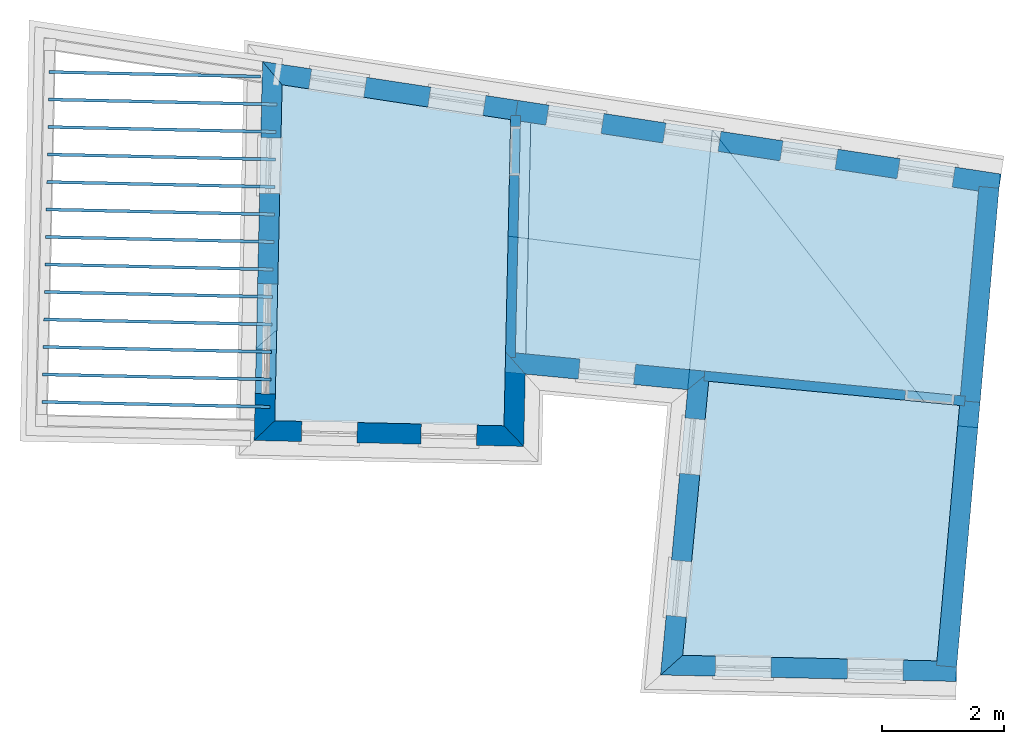
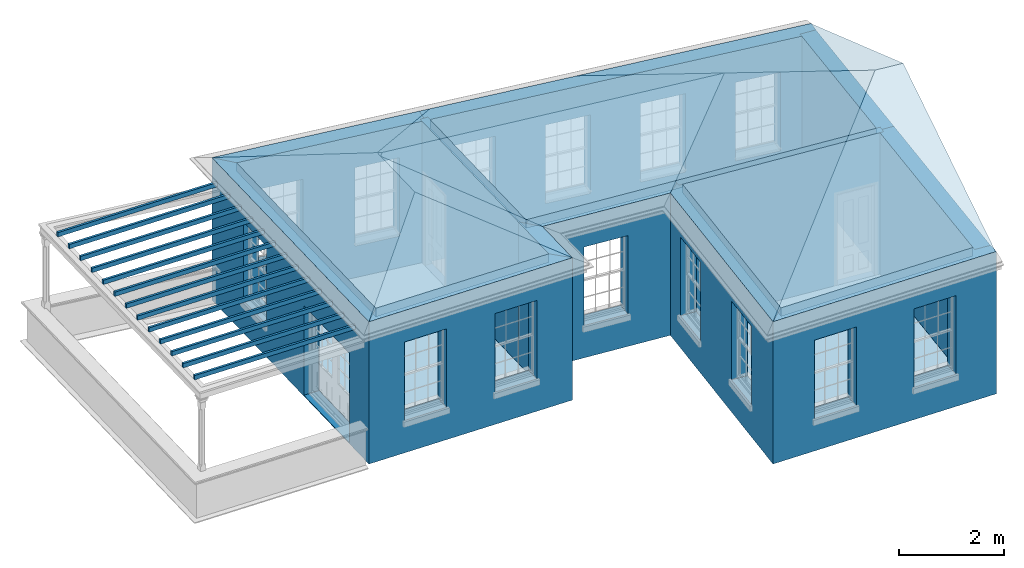
# One storey, part 1 of 12: 18 slabs, 12 walls, 3 roofs, 17 openings.
"""IFC2X3 building model written with IfcOpenShell, lengths in metres."""

from ifc_helpers import new_model, si_unit, frame, origin, place, context, subcontext, project, spatial, polyline, outline, extrude, faceted_brep, material, layer, layer_set, layer_usage, element, save


model = new_model("IFC2X3")

# Units and contexts
model_context = context("Model", 3, world=origin())
body_context = subcontext(model_context, "Body", "Model", "MODEL_VIEW")
ifc_project = project(units=[si_unit("PLANEANGLEUNIT", "RADIAN"), si_unit("MASSUNIT", "GRAM", prefix="KILO"), si_unit("FORCEUNIT", "NEWTON", prefix="KILO"), si_unit("LENGTHUNIT", "METRE")], contexts=[model_context])

# Site, building, storey
site_placement = place(None, origin())
site = spatial("IfcSite", under=ifc_project, at=site_placement, CompositionType="ELEMENT")
building_placement = place(None, origin())
building = spatial("IfcBuilding", under=site, at=building_placement, Name="Building plot-18", CompositionType="ELEMENT")
storey_placement = place(None, frame((0.0, 0.0, 9.9)))
storey = spatial("IfcBuildingStorey", under=building, at=storey_placement, Name="Floor 2", CompositionType="ELEMENT", Elevation=9.9)

# Slabs
slab_1_placement = place(storey_placement, frame((0.0, 0.0, 3.1)))
element("IfcSlab", 1, at=slab_1_placement, inside=storey, Name="Slab", ObjectType="Slab", PredefinedType="FLOOR", context=body_context, shape_type="SweptSolid", body=[
    extrude(outline(polyline([(96.7792255874086, 16.8916819408247), (100.939309623709, 16.8006913200882), (101.309526101752, 20.9794066379798), (97.2057969153529, 21.3743988576596), (96.7792255874086, 16.8916819408247)])), origin(), (0.0, 0.0, 1.0), 0.2),
])
slab_2_placement = place(storey_placement, frame((0.0, 0.0, 3.1)))
element("IfcSlab", 2, at=slab_2_placement, inside=storey, Name="Slab", ObjectType="Slab", PredefinedType="FLOOR", context=body_context, shape_type="SweptSolid", body=[
    extrude(outline(polyline([(93.9652937343678, 25.6552895166051), (90.2260155594004, 26.2254654944291), (90.1057958794453, 20.7290311654569), (93.8557511466322, 20.6470110056427), (93.9652937343678, 25.6552895166051)])), origin(), (0.0, 0.0, 1.0), 0.2),
])
slab_3_placement = place(storey_placement, frame((0.0, 0.0, 2.8)))
element("IfcSlab", 3, at=slab_3_placement, inside=storey, Name="Slab", ObjectType="Slab", PredefinedType="FLOOR", context=body_context, shape_type="SweptSolid", body=[
    extrude(outline(polyline([(86.4150109549581, 26.4611877456726), (86.4139176012794, 26.4111997013246), (89.8699378094766, 26.3356085783382), (89.8710311631553, 26.3855966226862), (86.4150109549581, 26.4611877456726)])), origin(), (0.0, 0.0, 1.0), 0.1),
])
slab_4_placement = place(storey_placement, frame((0.0, 0.0, 2.8)))
element("IfcSlab", 4, at=slab_4_placement, inside=storey, Name="Slab", ObjectType="Slab", PredefinedType="FLOOR", context=body_context, shape_type="SweptSolid", body=[
    extrude(outline(polyline([(86.4051707718502, 26.0112953465409), (86.4040774181715, 25.961307302193), (90.1384321710414, 25.8796283615637), (90.1395255247201, 25.9296164059116), (86.4051707718502, 26.0112953465409)])), origin(), (0.0, 0.0, 1.0), 0.1),
])
slab_5_placement = place(storey_placement, frame((0.0, 0.0, 2.8)))
element("IfcSlab", 5, at=slab_5_placement, inside=storey, Name="Slab", ObjectType="Slab", PredefinedType="FLOOR", context=body_context, shape_type="SweptSolid", body=[
    extrude(outline(polyline([(86.3953305887422, 25.5614029474093), (86.3942372350636, 25.5114149030614), (90.1285919879335, 25.4297359624321), (90.1296853416121, 25.47972400678), (86.3953305887422, 25.5614029474093)])), origin(), (0.0, 0.0, 1.0), 0.1),
])
slab_6_placement = place(storey_placement, frame((0.0, 0.0, 2.8)))
element("IfcSlab", 6, at=slab_6_placement, inside=storey, Name="Slab", ObjectType="Slab", PredefinedType="FLOOR", context=body_context, shape_type="SweptSolid", body=[
    extrude(outline(polyline([(86.3854904056343, 25.1115105482777), (86.3843970519556, 25.0615225039298), (90.1187518048255, 24.9798435633005), (90.1198451585042, 25.0298316076484), (86.3854904056343, 25.1115105482777)])), origin(), (0.0, 0.0, 1.0), 0.1),
])
slab_7_placement = place(storey_placement, frame((0.0, 0.0, 2.8)))
element("IfcSlab", 7, at=slab_7_placement, inside=storey, Name="Slab", ObjectType="Slab", PredefinedType="FLOOR", context=body_context, shape_type="SweptSolid", body=[
    extrude(outline(polyline([(86.3756502225263, 24.6616181491461), (86.3745568688477, 24.6116301047981), (90.1089116217176, 24.5299511641688), (90.1100049753963, 24.5799392085168), (86.3756502225263, 24.6616181491461)])), origin(), (0.0, 0.0, 1.0), 0.1),
])
slab_8_placement = place(storey_placement, frame((0.0, 0.0, 2.8)))
element("IfcSlab", 8, at=slab_8_placement, inside=storey, Name="Slab", ObjectType="Slab", PredefinedType="FLOOR", context=body_context, shape_type="SweptSolid", body=[
    extrude(outline(polyline([(86.3658100394184, 24.2117257500145), (86.3647166857397, 24.1617377056665), (90.0990714386096, 24.0800587650372), (90.1001647922883, 24.1300468093852), (86.3658100394184, 24.2117257500145)])), origin(), (0.0, 0.0, 1.0), 0.1),
])
slab_9_placement = place(storey_placement, frame((0.0, 0.0, 2.8)))
element("IfcSlab", 9, at=slab_9_placement, inside=storey, Name="Slab", ObjectType="Slab", PredefinedType="FLOOR", context=body_context, shape_type="SweptSolid", body=[
    extrude(outline(polyline([(86.3559698563105, 23.7618333508829), (86.3548765026318, 23.7118453065349), (90.0892312555017, 23.6301663659056), (90.0903246091804, 23.6801544102536), (86.3559698563105, 23.7618333508829)])), origin(), (0.0, 0.0, 1.0), 0.1),
])
slab_10_placement = place(storey_placement, frame((0.0, 0.0, 2.8)))
element("IfcSlab", 10, at=slab_10_placement, inside=storey, Name="Slab", ObjectType="Slab", PredefinedType="FLOOR", context=body_context, shape_type="SweptSolid", body=[
    extrude(outline(polyline([(86.3461296732025, 23.3119409517512), (86.3450363195239, 23.2619529074033), (90.0793910723938, 23.180273966774), (90.0804844260724, 23.2302620111219), (86.3461296732025, 23.3119409517512)])), origin(), (0.0, 0.0, 1.0), 0.1),
])
slab_11_placement = place(storey_placement, frame((0.0, 0.0, 2.8)))
element("IfcSlab", 11, at=slab_11_placement, inside=storey, Name="Slab", ObjectType="Slab", PredefinedType="FLOOR", context=body_context, shape_type="SweptSolid", body=[
    extrude(outline(polyline([(86.3362894900946, 22.8620485526196), (86.3351961364159, 22.8120605082717), (90.0695508892858, 22.7303815676424), (90.0706442429645, 22.7803696119903), (86.3362894900946, 22.8620485526196)])), origin(), (0.0, 0.0, 1.0), 0.1),
])
slab_12_placement = place(storey_placement, frame((0.0, 0.0, 2.8)))
element("IfcSlab", 12, at=slab_12_placement, inside=storey, Name="Slab", ObjectType="Slab", PredefinedType="FLOOR", context=body_context, shape_type="SweptSolid", body=[
    extrude(outline(polyline([(86.3264493069867, 22.412156153488), (86.325355953308, 22.3621681091401), (90.0597107061779, 22.2804891685108), (90.0608040598566, 22.3304772128587), (86.3264493069867, 22.412156153488)])), origin(), (0.0, 0.0, 1.0), 0.1),
])
slab_13_placement = place(storey_placement, frame((0.0, 0.0, 2.8)))
element("IfcSlab", 13, at=slab_13_placement, inside=storey, Name="Slab", ObjectType="Slab", PredefinedType="FLOOR", context=body_context, shape_type="SweptSolid", body=[
    extrude(outline(polyline([(86.3166091238787, 21.9622637543564), (86.3155157702001, 21.9122757100084), (90.0498705230699, 21.8305967693791), (90.0509638767486, 21.8805848137271), (86.3166091238787, 21.9622637543564)])), origin(), (0.0, 0.0, 1.0), 0.1),
])
slab_14_placement = place(storey_placement, frame((0.0, 0.0, 2.8)))
element("IfcSlab", 14, at=slab_14_placement, inside=storey, Name="Slab", ObjectType="Slab", PredefinedType="FLOOR", context=body_context, shape_type="SweptSolid", body=[
    extrude(outline(polyline([(86.3067689407708, 21.5123713552248), (86.3056755870921, 21.4623833108768), (90.040030339962, 21.3807043702475), (90.0411236936407, 21.4306924145955), (86.3067689407708, 21.5123713552248)])), origin(), (0.0, 0.0, 1.0), 0.1),
])
slab_15_placement = place(storey_placement, frame((0.0, 0.0, 2.8)))
element("IfcSlab", 15, at=slab_15_placement, inside=storey, Name="Slab", ObjectType="Slab", PredefinedType="FLOOR", context=body_context, shape_type="SweptSolid", body=[
    extrude(outline(polyline([(86.2969287576628, 21.0624789560932), (86.2958354039842, 21.0124909117452), (90.0301901568541, 20.9308119711159), (90.0312835105327, 20.9808000154639), (86.2969287576628, 21.0624789560932)])), origin(), (0.0, 0.0, 1.0), 0.1),
])
slab_16_placement = place(storey_placement, frame((0.0, 0.0, 3.1)))
element("IfcSlab", 16, at=slab_16_placement, inside=storey, Name="Slab", ObjectType="Slab", PredefinedType="FLOOR", context=body_context, shape_type="SweptSolid", body=[
    extrude(outline(polyline([(101.323646523775, 21.1387869662488), (101.620374439279, 24.4880206154953), (94.1248000238429, 25.6309675351122), (94.0418756596332, 21.8396721139234), (101.323646523775, 21.1387869662488)])), origin(), (0.0, 0.0, 1.0), 0.2),
])
slab_17_placement = place(storey_placement, origin())
element("IfcSlab", 17, at=slab_17_placement, inside=storey, Name="Slab", ObjectType="Slab", PredefinedType="FLOOR", context=body_context, shape_type="SweptSolid", body=[
    extrude(outline(polyline([(96.7792255874086, 16.8916819408247), (100.939309623709, 16.8006913200882), (101.309526101752, 20.9794066379798), (97.2057969153529, 21.3743988576596), (96.7792255874086, 16.8916819408247)])), origin(), (0.0, 0.0, 1.0), 0.02),
])
slab_18_placement = place(storey_placement, origin())
element("IfcSlab", 18, at=slab_18_placement, inside=storey, Name="Slab", ObjectType="Slab", PredefinedType="FLOOR", context=body_context, shape_type="SweptSolid", body=[
    extrude(outline(polyline([(93.9652937343678, 25.6552895166051), (90.2260155594004, 26.2254654944291), (90.1057958794453, 20.7290311654569), (93.8557511466322, 20.6470110056427), (93.9652937343678, 25.6552895166051)])), origin(), (0.0, 0.0, 1.0), 0.02),
])

# Wall, openings
ifc_material_1 = material(Name="Masonry")
ifc_layer_1 = layer(ifc_material_1, 0.33, ventilated=False)
ifc_layer_set_1 = layer_set([ifc_layer_1], Name="My Wall")
ifc_layer_usage_1 = layer_usage(ifc_layer_set_1, "AXIS2", "NEGATIVE", 0.08)
wall_1_placement = place(storey_placement, origin())
wall_1 = element("IfcWallStandardCase", 19, at=wall_1_placement, inside=storey, material=ifc_layer_usage_1, Name="exterior", context=body_context, shape_type="SweptSolid", body=[
    extrude(outline(polyline([(101.941775393575, 24.4390124661107), (101.991519769301, 24.7652416755381), (94.0844961381432, 25.9709275645287), (94.0347517624171, 25.6446983551013), (101.941775393575, 24.4390124661107)])), origin(), (0.0, 0.0, 1.0), 3.3),
])
opening_1_placement = place(storey_placement, frame((0.0, 0.0, 0.75)))
element("IfcOpeningElement", 20, at=opening_1_placement, cuts=wall_1, Name="Opening", ObjectType="Opening", context=body_context, shape_type="SweptSolid", body=[
    extrude(outline(polyline([(101.236692272156, 24.880339960858), (100.337090512825, 25.017513845436), (100.287346137099, 24.6912846360086), (101.186947896429, 24.5541107514306), (101.236692272156, 24.880339960858)])), origin(), (0.0, 0.0, 1.0), 1.82),
])
opening_2_placement = place(storey_placement, frame((0.0, 0.0, 0.75)))
element("IfcOpeningElement", 21, at=opening_2_placement, cuts=wall_1, Name="Opening", ObjectType="Opening", context=body_context, shape_type="SweptSolid", body=[
    extrude(outline(polyline([(99.3217221994849, 25.1723401498242), (98.4221204401548, 25.3095140344022), (98.3723760644287, 24.9832848249748), (99.2719778237588, 24.8461109403968), (99.3217221994849, 25.1723401498242)])), origin(), (0.0, 0.0, 1.0), 1.82),
])
opening_3_placement = place(storey_placement, frame((0.0, 0.0, 0.75)))
element("IfcOpeningElement", 22, at=opening_3_placement, cuts=wall_1, Name="Opening", ObjectType="Opening", context=body_context, shape_type="SweptSolid", body=[
    extrude(outline(polyline([(97.4067521268142, 25.4643403387904), (96.5071503674841, 25.6015142233684), (96.4574059917581, 25.275285013941), (97.3570077510882, 25.138111129363), (97.4067521268142, 25.4643403387904)])), origin(), (0.0, 0.0, 1.0), 1.82),
])
opening_4_placement = place(storey_placement, frame((0.0, 0.0, 0.75)))
element("IfcOpeningElement", 23, at=opening_4_placement, cuts=wall_1, Name="Opening", ObjectType="Opening", context=body_context, shape_type="SweptSolid", body=[
    extrude(outline(polyline([(95.4917820541436, 25.7563405277566), (94.5921802948135, 25.8935144123346), (94.5424359190874, 25.5672852029072), (95.4420376784175, 25.4301113183292), (95.4917820541436, 25.7563405277566)])), origin(), (0.0, 0.0, 1.0), 1.82),
])

wall_2_placement = place(storey_placement, origin())
wall_2 = element("IfcWallStandardCase", 24, at=wall_2_placement, inside=storey, material=ifc_layer_usage_1, Name="exterior", context=body_context, shape_type="SweptSolid", body=[
    extrude(outline(polyline([(94.0347517624171, 25.6446983551013), (94.0844961381432, 25.9709275645287), (89.9043108567451, 26.6083343363116), (90.2260155594004, 26.2254654944291), (94.0347517624171, 25.6446983551013)])), origin(), (0.0, 0.0, 1.0), 3.3),
])
opening_5_placement = place(storey_placement, frame((0.0, 0.0, 0.75)))
element("IfcOpeningElement", 25, at=opening_5_placement, cuts=wall_2, Name="Opening", ObjectType="Opening", context=body_context, shape_type="SweptSolid", body=[
    extrude(outline(polyline([(93.5596009016976, 26.050965112069), (92.6599991423675, 26.1881389966469), (92.6102547666415, 25.8619097872195), (93.5098565259716, 25.7247359026416), (93.5596009016976, 26.050965112069)])), origin(), (0.0, 0.0, 1.0), 1.82),
])
opening_6_placement = place(storey_placement, frame((0.0, 0.0, 0.75)))
element("IfcOpeningElement", 26, at=opening_6_placement, cuts=wall_2, Name="Opening", ObjectType="Opening", context=body_context, shape_type="SweptSolid", body=[
    extrude(outline(polyline([(91.6102086694764, 26.3482140917274), (90.7106069101463, 26.4853879763053), (90.6608625344202, 26.1591587668779), (91.5604642937503, 26.0219848823), (91.6102086694764, 26.3482140917274)])), origin(), (0.0, 0.0, 1.0), 1.82),
])

wall_3_placement = place(storey_placement, origin())
wall_3 = element("IfcWallStandardCase", 27, at=wall_3_placement, inside=storey, material=ifc_layer_usage_1, Name="exterior", context=body_context, shape_type="SweptSolid", body=[
    extrude(outline(polyline([(90.2260155594004, 26.2254654944291), (89.9043108567451, 26.6083343363116), (89.7686586524696, 20.406326207039), (90.1057958794453, 20.7290311654569), (90.2260155594004, 26.2254654944291)])), origin(), (0.0, 0.0, 1.0), 3.3),
])
opening_7_placement = place(storey_placement, frame((0.0, 0.0, 0.75)))
element("IfcOpeningElement", 28, at=opening_7_placement, cuts=wall_3, Name="Opening", ObjectType="Opening", context=body_context, shape_type="SweptSolid", body=[
    extrude(outline(polyline([(89.8770456128179, 25.3617695245838), (89.8571465758663, 24.451987117451), (90.1870676685628, 24.4447709831718), (90.2069667055144, 25.3545533903047), (89.8770456128179, 25.3617695245838)])), origin(), (0.0, 0.0, 1.0), 1.82),
])
opening_8_placement = place(storey_placement, frame((0.0, 0.0, 0.0199999999999996)))
element("IfcOpeningElement", 29, at=opening_8_placement, cuts=wall_3, Name="Opening", ObjectType="Opening", context=body_context, shape_type="SweptSolid", body=[
    extrude(outline(polyline([(89.8247960115718, 22.9729218577882), (89.7854352791401, 21.1733522612618), (90.1153563718366, 21.1661361269826), (90.1547171042684, 22.9657057235091), (89.8247960115718, 22.9729218577882)])), origin(), (0.0, 0.0, 1.0), 2.08),
])

wall_4_placement = place(storey_placement, origin())
wall_4 = element("IfcWallStandardCase", 30, at=wall_4_placement, inside=storey, material=ifc_layer_usage_1, Name="exterior", context=body_context, shape_type="SweptSolid", body=[
    extrude(outline(polyline([(90.1057958794453, 20.7290311654569), (89.7686586524696, 20.406326207039), (94.1784561050496, 20.309873778667), (93.8557511466322, 20.6470110056427), (90.1057958794453, 20.7290311654569)])), origin(), (0.0, 0.0, 1.0), 3.3),
])
opening_9_placement = place(storey_placement, frame((0.0, 0.0, 0.75)))
element("IfcOpeningElement", 31, at=opening_9_placement, cuts=wall_4, Name="Opening", ObjectType="Opening", context=body_context, shape_type="SweptSolid", body=[
    extrude(outline(polyline([(90.5411869229181, 20.3894292342252), (91.4509693300509, 20.3695301972735), (91.4581854643301, 20.6994512899701), (90.5484030571972, 20.7193503269217), (90.5411869229181, 20.3894292342252)])), origin(), (0.0, 0.0, 1.0), 1.82),
])
opening_10_placement = place(storey_placement, frame((0.0, 0.0, 0.75)))
element("IfcOpeningElement", 32, at=opening_10_placement, cuts=wall_4, Name="Opening", ObjectType="Opening", context=body_context, shape_type="SweptSolid", body=[
    extrude(outline(polyline([(92.4961454274683, 20.3466697884325), (93.4059278346011, 20.3267707514808), (93.4131439688803, 20.6566918441774), (92.5033615617474, 20.676590881129), (92.4961454274683, 20.3466697884325)])), origin(), (0.0, 0.0, 1.0), 1.82),
])

# Wall
wall_5_placement = place(storey_placement, origin())
element("IfcWallStandardCase", 33, at=wall_5_placement, inside=storey, material=ifc_layer_usage_1, Name="exterior", context=body_context, shape_type="SweptSolid", body=[
    extrude(outline(polyline([(93.8557511466322, 20.6470110056427), (94.1784561050496, 20.309873778667), (94.2043231076959, 21.492511108805), (93.8821736056846, 21.8550437590575), (93.8557511466322, 20.6470110056427)])), origin(), (0.0, 0.0, 1.0), 3.3),
])

# Wall, opening
wall_6_placement = place(storey_placement, origin())
wall_6 = element("IfcWallStandardCase", 34, at=wall_6_placement, inside=storey, material=ifc_layer_usage_1, Name="exterior", context=body_context, shape_type="SweptSolid", body=[
    extrude(outline(polyline([(93.8821736056846, 21.8550437590575), (94.2043231076959, 21.492511108805), (96.8612105097509, 21.2367803320634), (97.2209539104425, 21.533679413678), (93.8821736056846, 21.8550437590575)])), origin(), (0.0, 0.0, 1.0), 3.3),
])
opening_11_placement = place(storey_placement, frame((0.0, 0.0, 0.75)))
element("IfcOpeningElement", 35, at=opening_11_placement, cuts=wall_6, Name="Opening", ObjectType="Opening", context=body_context, shape_type="SweptSolid", body=[
    extrude(outline(polyline([(95.0701477438461, 21.4091737394635), (95.9759614837646, 21.3219873381452), (96.0075785303965, 21.65046924383), (95.101764790478, 21.7376556451482), (95.0701477438461, 21.4091737394635)])), origin(), (0.0, 0.0, 1.0), 1.82),
])

# Wall, openings
wall_7_placement = place(storey_placement, origin())
wall_7 = element("IfcWallStandardCase", 36, at=wall_7_placement, inside=storey, material=ifc_layer_usage_1, Name="exterior", context=body_context, shape_type="SweptSolid", body=[
    extrude(outline(polyline([(97.2209539104425, 21.533679413678), (96.8612105097509, 21.2367803320634), (96.4170785766712, 16.5695240039888), (96.7792255874086, 16.8916819408247), (97.2209539104425, 21.533679413678)])), origin(), (0.0, 0.0, 1.0), 3.3),
])
opening_12_placement = place(storey_placement, frame((0.0, 0.0, 0.75)))
element("IfcOpeningElement", 37, at=opening_12_placement, cuts=wall_7, Name="Opening", ObjectType="Opening", context=body_context, shape_type="SweptSolid", body=[
    extrude(outline(polyline([(96.8173925916487, 20.776310277304), (96.7311872326308, 19.8704026462087), (97.0597031867643, 19.8391413621693), (97.1459085457821, 20.7450489932646), (96.8173925916487, 20.776310277304)])), origin(), (0.0, 0.0, 1.0), 1.82),
])
opening_13_placement = place(storey_placement, frame((0.0, 0.0, 0.75)))
element("IfcOpeningElement", 38, at=opening_13_placement, cuts=wall_7, Name="Opening", ObjectType="Opening", context=body_context, shape_type="SweptSolid", body=[
    extrude(outline(polyline([(96.5962370834595, 18.4522498614566), (96.5100317244417, 17.5463422303613), (96.8385476785751, 17.5150809463219), (96.924753037593, 18.4209885774172), (96.5962370834595, 18.4522498614566)])), origin(), (0.0, 0.0, 1.0), 1.82),
])

wall_8_placement = place(storey_placement, origin())
wall_8 = element("IfcWallStandardCase", 39, at=wall_8_placement, inside=storey, material=ifc_layer_usage_1, Name="exterior", context=body_context, shape_type="SweptSolid", body=[
    extrude(outline(polyline([(96.7792255874086, 16.8916819408247), (96.4170785766712, 16.5695240039888), (101.256865456868, 16.463666716343), (101.264081591148, 16.7935878090395), (96.7792255874086, 16.8916819408247)])), origin(), (0.0, 0.0, 1.0), 3.3),
])
opening_14_placement = place(storey_placement, frame((0.0, 0.0, 0.75)))
element("IfcOpeningElement", 40, at=opening_14_placement, cuts=wall_8, Name="Opening", ObjectType="Opening", context=body_context, shape_type="SweptSolid", body=[
    extrude(outline(polyline([(97.3113143084341, 16.5499650086398), (98.2210967155669, 16.5300659716882), (98.2283128498461, 16.8599870643847), (97.3185304427132, 16.8798861013363), (97.3113143084341, 16.5499650086398)])), origin(), (0.0, 0.0, 1.0), 1.82),
])
opening_15_placement = place(storey_placement, frame((0.0, 0.0, 0.75)))
element("IfcOpeningElement", 41, at=opening_15_placement, cuts=wall_8, Name="Opening", ObjectType="Opening", context=body_context, shape_type="SweptSolid", body=[
    extrude(outline(polyline([(99.4717941238529, 16.5027103383547), (100.381576530986, 16.482811301403), (100.388792665265, 16.8127323940996), (99.479010258132, 16.8326314310512), (99.4717941238529, 16.5027103383547)])), origin(), (0.0, 0.0, 1.0), 1.82),
])

# Walls
wall_9_placement = place(storey_placement, origin())
element("IfcWallStandardCase", 42, at=wall_9_placement, inside=storey, material=ifc_layer_usage_1, Name="party", context=body_context, shape_type="SweptSolid", body=[
    extrude(outline(polyline([(100.932704135606, 16.7261337140522), (101.26141659076, 16.6970111828008), (101.645245171745, 21.0293693190009), (101.316532716591, 21.0584918502523), (100.932704135606, 16.7261337140522)])), origin(), (0.0, 0.0, 1.0), 3.3),
])
wall_10_placement = place(storey_placement, origin())
element("IfcWallStandardCase", 43, at=wall_10_placement, inside=storey, material=ifc_layer_usage_1, Name="party", context=body_context, shape_type="SweptSolid", body=[
    extrude(outline(polyline([(101.316532716591, 21.0584918502523), (101.645245171745, 21.0293693190009), (101.955715882938, 24.5337209445133), (101.627003427784, 24.5628434757647), (101.316532716591, 21.0584918502523)])), origin(), (0.0, 0.0, 1.0), 3.3),
])

# Wall, opening
ifc_material_2 = material(Name="Masonry")
ifc_layer_2 = layer(ifc_material_2, 0.16, ventilated=False)
ifc_layer_set_2 = layer_set([ifc_layer_2], Name="My Wall")
ifc_layer_usage_2 = layer_usage(ifc_layer_set_2, "AXIS2", "NEGATIVE", 0.08)
wall_11_placement = place(storey_placement, origin())
wall_11 = element("IfcWallStandardCase", 44, at=wall_11_placement, inside=storey, material=ifc_layer_usage_2, Name="interior", context=body_context, shape_type="SweptSolid", body=[
    extrude(outline(polyline([(93.8802895837003, 21.7689064218516), (94.0402513256137, 21.7654076900798), (94.1267918759741, 25.7220348581675), (93.9668301340607, 25.7255335899393), (93.8802895837003, 21.7689064218516)])), origin(), (0.0, 0.0, 1.0), 3.3),
])
opening_16_placement = place(storey_placement, frame((0.0, 0.0, 0.0199999999999996)))
element("IfcOpeningElement", 45, at=opening_16_placement, cuts=wall_11, Name="Opening", ObjectType="Opening", context=body_context, shape_type="SweptSolid", body=[
    extrude(outline(polyline([(94.1053621438724, 24.7422691889476), (94.122855802731, 25.5420778985149), (93.9628940608175, 25.5455766302866), (93.9454004019589, 24.7457679207193), (94.1053621438724, 24.7422691889476)])), origin(), (0.0, 0.0, 1.0), 2.1),
])

wall_12_placement = place(storey_placement, origin())
wall_12 = element("IfcWallStandardCase", 46, at=wall_12_placement, inside=storey, material=ifc_layer_usage_2, Name="interior", context=body_context, shape_type="SweptSolid", body=[
    extrude(outline(polyline([(101.38855584593, 20.9717998655405), (101.403885323084, 21.1310638198119), (97.1414081276401, 21.5413358558768), (97.1260786504853, 21.3820719016054), (101.38855584593, 20.9717998655405)])), origin(), (0.0, 0.0, 1.0), 3.3),
])
opening_17_placement = place(storey_placement, frame((0.0, 0.0, 0.0199999999999996)))
element("IfcOpeningElement", 47, at=opening_17_placement, cuts=wall_12, Name="Opening", ObjectType="Opening", context=body_context, shape_type="SweptSolid", body=[
    extrude(outline(polyline([(101.224713374529, 21.1483094816111), (100.428393603172, 21.2249568673854), (100.413064126017, 21.065692913114), (101.209383897374, 20.9890455273397), (101.224713374529, 21.1483094816111)])), origin(), (0.0, 0.0, 1.0), 2.1),
])

# Roofs
roof_1_placement = place(building_placement, origin())
element("IfcRoof", 48, at=roof_1_placement, inside=storey, Name="Roof", ShapeType="FREEFORM", context=body_context, shape_type="Brep", held_by="IfcProductRepresentation", body=[
    faceted_brep([(89.801685, 21.916274, 13.2), (101.623015, 20.778447, 13.2), (101.79955, 22.771046, 14.028571), (92.117613, 23.974227, 14.14042), (101.976431, 24.767542, 13.2), (89.904311, 26.608334, 13.2)], [[[0, 1, 2, 3]], [[4, 5, 3, 2]], [[5, 4, 1, 0]], [[5, 0, 3]], [[1, 4, 2]]]),
])
roof_2_placement = place(building_placement, origin())
element("IfcRoof", 49, at=roof_2_placement, inside=storey, Name="Roof", ShapeType="FREEFORM", context=body_context, shape_type="Brep", held_by="IfcProductRepresentation", body=[
    faceted_brep([(96.417079, 16.569524, 13.2), (101.240774, 16.464019, 13.2), (101.608645, 20.616257, 14.922834), (101.023254, 20.667075, 14.938577), (101.976431, 24.767542, 13.2), (97.26555, 25.485871, 13.2)], [[[0, 1, 2, 3]], [[4, 5, 3, 2]], [[5, 4, 1, 0]], [[5, 0, 3]], [[1, 4, 2]]]),
])
roof_3_placement = place(building_placement, origin())
element("IfcRoof", 50, at=roof_3_placement, inside=storey, Name="Roof", ShapeType="FREEFORM", context=body_context, shape_type="Brep", held_by="IfcProductRepresentation", body=[
    faceted_brep([(94.178456, 20.309874, 13.2), (94.301552, 25.93783, 13.2), (92.054299, 24.04958, 14.113517), (92.021784, 22.562999, 14.113517), (89.904311, 26.608334, 13.2), (89.768659, 20.406326, 13.2)], [[[0, 1, 2, 3]], [[4, 5, 3, 2]], [[5, 4, 1, 0]], [[5, 0, 3]], [[1, 4, 2]]]),
])

save(model, "model.ifc")
